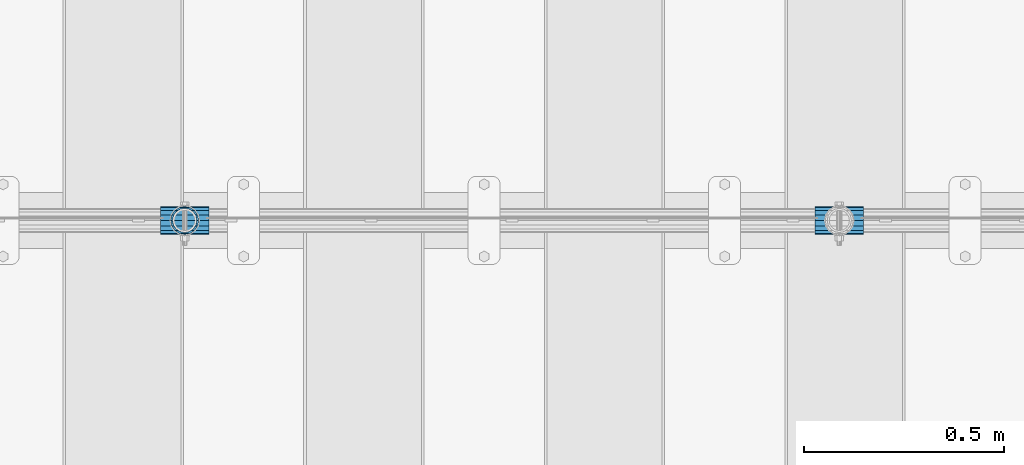
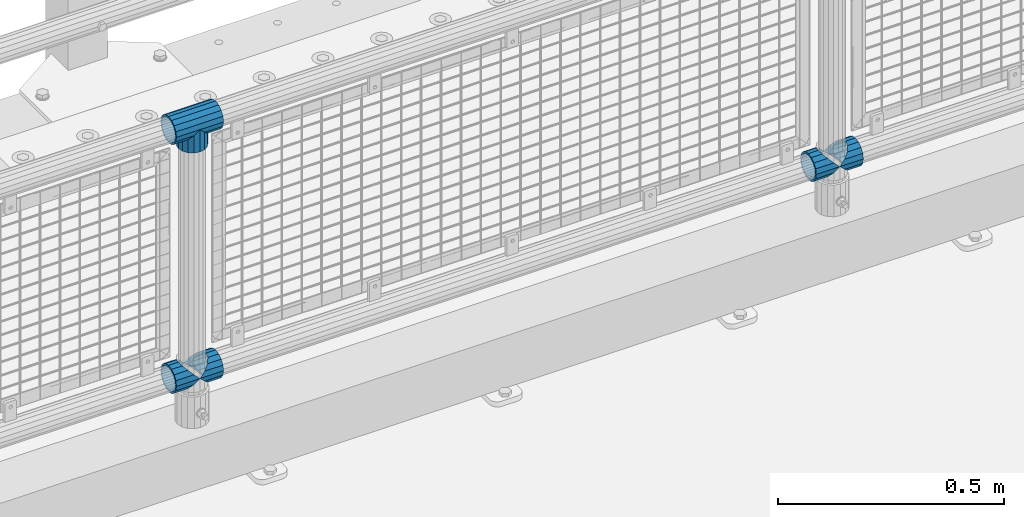
# One storey, part 151 of 242: 6 beams.
"""IFC2X3 building model written with IfcOpenShell, lengths in millimetres."""

from ifc_helpers import new_model, si_unit, frame, origin_with_axes, place, context, subcontext, project, spatial, faceted_brep, material, type_object, element, save


model = new_model("IFC2X3")

# Units and contexts
model_context = context("Model", 3, precision=1e-05, world=origin_with_axes())
body_context = subcontext(model_context, "Body", "Model", "MODEL_VIEW")
ifc_project = project(units=[si_unit("LENGTHUNIT", "METRE", prefix="MILLI"), si_unit("AREAUNIT", "SQUARE_METRE"), si_unit("VOLUMEUNIT", "CUBIC_METRE"), si_unit("MASSUNIT", "GRAM", prefix="KILO"), si_unit("TIMEUNIT", "SECOND"), si_unit("PLANEANGLEUNIT", "RADIAN"), si_unit("SOLIDANGLEUNIT", "STERADIAN"), si_unit("THERMODYNAMICTEMPERATUREUNIT", "DEGREE_CELSIUS"), si_unit("LUMINOUSINTENSITYUNIT", "LUMEN")], contexts=[model_context])

# Site, building, storey
site_placement = place(None, origin_with_axes())
site = spatial("IfcSite", under=ifc_project, at=site_placement, CompositionType="ELEMENT")
building_placement = place(site_placement, origin_with_axes())
building = spatial("IfcBuilding", under=site, at=building_placement, Name="Standard", CompositionType="ELEMENT")
storey_placement = place(building_placement, origin_with_axes())
storey = spatial("IfcBuildingStorey", under=building, at=storey_placement, Name="Undefined", CompositionType="ELEMENT", Elevation=0.0)

# Beams
ifc_material = material(Name="Misc_Undefined")
beam_type = type_object("IfcBeamType", PredefinedType="NOTDEFINED")
beam_1_placement = place(storey_placement, frame((-33724.15, -19335.5, 298.17), z_axis=(0.0, 1.0, 0.0), x_axis=(1.0, 0.0, 0.0)))
element("IfcBeam", 1, at=beam_1_placement, inside=storey, type_object=beam_type, material=ifc_material, context=body_context, shape_type="Brep", body=[
    faceted_brep([(60.1500000000015, 0.0, -35.1500000000015), (46.698677352364, 13.4513226476329, -32.4743655677703), (46.698677352364, -13.4513226476329, -32.4743655677703), (33.0273231408901, 21.4606908090117, 21.46069080901), (27.6756344322275, 26.8123795176754, 13.4513226476338), (27.6756344322275, 32.4743655677717, 13.4513226476338), (35.2951966412911, 24.8548033587072, 24.8548033587067), (35.2951966412911, 16.3810424080013, 24.8548033587067), (27.3102561882806, 28.0397438117175, 11.614442172282), (24.9999999999964, 30.35, 0.0), (24.9999999999964, 35.15, 0.0), (27.6756344322275, 26.8123795176754, -13.4513226476338), (27.6756344322275, 32.4743655677717, -13.4513226476338), (27.310256188277, 28.0397438117175, -11.614442172282), (35.2951966412911, 16.3810424080013, -24.8548033587067), (35.2951966412911, 24.8548033587072, -24.8548033587067), (33.0273231408937, 21.4606908090117, -21.46069080901), (40.061796877013, 11.6144421722805, -28.0397438117179), (43.5193396016293, 0.0, -30.3499999999985), (40.061796877013, -11.6144421722805, -28.0397438117179), (35.2951966412911, -16.3810424080078, -24.8548033587067), (35.2951966412911, -24.8548033587072, -24.8548033587067), (33.0273231408937, -21.4606908090117, -21.46069080901), (27.6756344322275, -26.8123795176754, -13.4513226476338), (27.6756344322275, -32.4743655677717, -13.4513226476338), (27.310256188277, -28.0397438117175, -11.614442172282), (24.9999999999964, -30.35, 0.0), (24.9999999999964, -35.15, 0.0), (27.3102561882806, -28.0397438117175, 11.614442172282), (27.6756344322275, -26.8123795176775, 13.4513226476338), (27.6756344322275, -32.4743655677717, 13.4513226476338), (33.0273231408901, -21.4606908090117, 21.46069080901), (35.2951966412911, -16.3810424080045, 24.8548033587067), (35.2951966412911, -24.8548033587072, 24.8548033587067), (60.1500000000015, 0.0, 35.1500000000015), (46.698677352364, -13.4513226476329, 32.4743655677703), (46.698677352364, 13.4513226476329, 32.4743655677703), (40.0617968770166, -11.6144421722805, 28.0397438117179), (43.5193396016257, 0.0, 30.3499999999985), (40.0617968770166, 11.6144421722805, 28.0397438117179), (0.0, -32.4743655677703, -13.4513226476338), (0.0, -24.8548033587067, -24.8548033587067), (0.0, -13.4513226476338, -32.4743655677739), (0.0, 0.0, -35.1500000000015), (0.0, 13.4513226476338, -32.4743655677739), (0.0, 24.8548033587067, -24.8548033587067), (0.0, 32.4743655677703, -13.4513226476338), (0.0, 35.1500000000015, 0.0), (0.0, 32.4743655677703, 13.4513226476338), (0.0, 24.8548033587067, 24.8548033587067), (0.0, 13.4513226476338, 32.4743655677739), (0.0, 0.0, 35.1500000000015), (0.0, -32.4743655677703, 13.4513226476338), (0.0, -35.1500000000015, 0.0), (0.0, -24.8548033587067, 24.8548033587067), (0.0, -13.4513226476338, 32.4743655677739), (0.0, -28.0397438117179, -11.6144421722784), (0.0, -21.46069080901, -21.4606908090136), (0.0, -11.614442172282, -28.0397438117143), (0.0, 0.0, -30.3499999999985), (0.0, 11.614442172282, -28.0397438117143), (0.0, 21.46069080901, -21.4606908090136), (0.0, 28.0397438117179, -11.6144421722784), (0.0, 30.3499999999985, 0.0), (0.0, 28.0397438117179, 11.6144421722784), (0.0, 21.46069080901, 21.4606908090136), (0.0, 11.614442172282, 28.0397438117143), (0.0, 0.0, 30.3499999999985), (0.0, -11.614442172282, 28.0397438117143), (0.0, -21.46069080901, 21.4606908090136), (0.0, -28.0397438117179, 11.6144421722784), (0.0, -30.3499999999985, 0.0)], [[[0, 1, 2]], [[3, 4, 5, 6, 7]], [[8, 9, 10, 5, 4]], [[11, 12, 10, 9, 13]], [[14, 15, 12, 11, 16]], [[2, 1, 15, 14, 17, 18, 19, 20, 21]], [[21, 20, 22, 23, 24]], [[24, 23, 25, 26, 27]], [[27, 26, 28, 29, 30]], [[30, 29, 31, 32, 33]], [[34, 35, 36]], [[33, 32, 37, 38, 39, 7, 6, 36, 35]], [[40, 41, 21, 24]], [[41, 42, 2, 21]], [[42, 43, 0, 2]], [[43, 44, 1, 0]], [[44, 45, 15, 1]], [[45, 46, 12, 15]], [[46, 47, 10, 12]], [[47, 48, 5, 10]], [[48, 49, 6, 5]], [[49, 50, 36, 6]], [[50, 51, 34, 36]], [[52, 53, 27, 30]], [[54, 52, 30, 33]], [[55, 54, 33, 35]], [[51, 55, 35, 34]], [[53, 40, 24, 27]], [[52, 54, 55, 51, 50, 49, 48, 47, 46, 45, 44, 43, 42, 41, 40, 53], [56, 57, 58, 59, 60, 61, 62, 63, 64, 65, 66, 67, 68, 69, 70, 71]], [[68, 67, 38, 37]], [[31, 69, 68, 37, 32]], [[28, 70, 69, 31, 29]], [[71, 70, 28, 26]], [[56, 71, 26, 25]], [[57, 56, 25, 23, 22]], [[58, 57, 22, 20, 19]], [[59, 58, 19, 18]], [[60, 59, 18, 17]], [[16, 61, 60, 17, 14]], [[13, 62, 61, 16, 11]], [[63, 62, 13, 9]], [[64, 63, 9, 8]], [[65, 64, 8, 4, 3]], [[66, 65, 3, 7, 39]], [[67, 66, 39, 38]]]),
])
beam_2_placement = place(storey_placement, frame((-33664.0, -19335.5, 298.17), z_axis=(0.0, 1.0, 0.0), x_axis=(1.0, 0.0, 0.0)))
element("IfcBeam", 2, at=beam_2_placement, inside=storey, type_object=beam_type, material=ifc_material, context=body_context, shape_type="Brep", body=[
    faceted_brep([(13.4513226476338, 13.4513226476329, 32.4743655677703), (13.4513226476338, -13.4513226476329, 32.4743655677703), (0.0, 0.0, 35.1500000000015), (27.122676859115, -21.4606908090117, -21.46069080901), (24.8548033587067, -16.3810424080019, -24.8548033587067), (24.8548033587067, -24.8548033587072, -24.8548033587067), (32.4743655677739, -32.4743655677717, -13.4513226476338), (32.4743655677739, -26.8123795176754, -13.4513226476338), (0.0, 0.0, -35.1500000000015), (13.4513226476338, -13.4513226476329, -32.4743655677703), (13.4513226476338, 13.4513226476329, -32.4743655677703), (20.0882031229849, -11.6144421722805, -28.0397438117179), (16.6306603983758, 0.0, -30.3499999999985), (20.0882031229849, 11.6144421722805, -28.0397438117179), (24.8548033587067, 16.3810424079986, -24.8548033587067), (24.8548033587067, 24.8548033587072, -24.8548033587067), (27.122676859115, 21.4606908090117, -21.46069080901), (32.4743655677739, 26.8123795176776, -13.4513226476338), (32.4743655677739, 32.4743655677717, -13.4513226476338), (32.8397438117099, 28.0397438117175, -11.614442172282), (35.1500000000015, 30.35, 0.0), (35.1500000000015, 35.1499999999996, 0.0), (32.8397438117172, 28.0397438117175, 11.614442172282), (32.4743655677739, 26.8123795176754, 13.4513226476338), (32.4743655677739, 32.4743655677717, 13.4513226476338), (27.1226768591077, 21.4606908090117, 21.46069080901), (24.8548033587067, 16.3810424080019, 24.8548033587067), (24.8548033587067, 24.8548033587072, 24.8548033587067), (20.0882031229849, 11.6144421722805, 28.0397438117179), (16.6306603983685, 0.0, 30.3499999999985), (20.0882031229849, -11.6144421722805, 28.0397438117179), (24.8548033587067, -16.3810424080019, 24.8548033587067), (24.8548033587067, -24.8548033587072, 24.8548033587067), (32.4743655677739, -26.8123795176754, 13.4513226476338), (32.4743655677739, -32.4743655677717, 13.4513226476338), (27.1226768591077, -21.4606908090117, 21.46069080901), (35.1500000000015, -30.35, 0.0), (35.1500000000015, -35.15, 0.0), (32.8397438117172, -28.0397438117175, 11.614442172282), (32.8397438117099, -28.0397438117175, -11.614442172282), (60.1500000000015, -24.8548033587072, -24.8548033587067), (60.1500000000015, -32.4743655677717, -13.4513226476338), (60.1500000000015, -13.4513226476329, -32.4743655677703), (60.1500000000015, 0.0, -35.1500000000015), (60.1500000000015, 13.4513226476329, -32.4743655677703), (60.1500000000015, 24.8548033587072, -24.8548033587067), (60.1500000000015, 32.4743655677717, -13.4513226476338), (60.1500000000015, 35.15, 0.0), (60.1500000000015, 32.4743655677717, 13.4513226476338), (60.1500000000015, 24.8548033587072, 24.8548033587067), (60.1500000000015, 13.4513226476329, 32.4743655677703), (60.1500000000015, 0.0, 35.1500000000015), (60.1500000000015, -13.4513226476329, 32.4743655677703), (60.1500000000015, -24.8548033587072, 24.8548033587067), (60.1500000000015, -32.4743655677717, 13.4513226476338), (60.1500000000015, -35.15, 0.0), (60.1500000000015, -21.4606908090117, 21.46069080901), (60.1500000000015, -11.6144421722805, 28.0397438117179), (60.1500000000015, 0.0, 30.3499999999985), (60.1500000000015, 11.6144421722805, 28.0397438117179), (60.1500000000015, 21.4606908090117, 21.46069080901), (60.1500000000015, 28.0397438117175, 11.614442172282), (60.1500000000015, 30.35, 0.0), (60.1500000000015, 28.0397438117175, -11.614442172282), (60.1500000000015, 21.4606908090117, -21.46069080901), (60.1500000000015, 11.6144421722805, -28.0397438117179), (60.1500000000015, 0.0, -30.3499999999985), (60.1500000000015, -11.6144421722805, -28.0397438117179), (60.1500000000015, -21.4606908090117, -21.46069080901), (60.1500000000015, -28.0397438117175, -11.614442172282), (60.1500000000015, -30.35, 0.0), (60.1500000000015, -28.0397438117175, 11.614442172282)], [[[0, 1, 2]], [[3, 4, 5, 6, 7]], [[8, 9, 10]], [[10, 9, 5, 4, 11, 12, 13, 14, 15]], [[15, 14, 16, 17, 18]], [[18, 17, 19, 20, 21]], [[21, 20, 22, 23, 24]], [[24, 23, 25, 26, 27]], [[27, 26, 28, 29, 30, 31, 32, 1, 0]], [[33, 34, 32, 31, 35]], [[36, 37, 34, 33, 38]], [[39, 7, 6, 37, 36]], [[40, 41, 6, 5]], [[42, 40, 5, 9]], [[43, 42, 9, 8]], [[44, 43, 8, 10]], [[45, 44, 10, 15]], [[46, 45, 15, 18]], [[47, 46, 18, 21]], [[48, 47, 21, 24]], [[49, 48, 24, 27]], [[50, 49, 27, 0]], [[51, 50, 0, 2]], [[52, 51, 2, 1]], [[53, 52, 1, 32]], [[54, 53, 32, 34]], [[55, 54, 34, 37]], [[41, 55, 37, 6]], [[40, 42, 43, 44, 45, 46, 47, 48, 49, 50, 51, 52, 53, 54, 55, 41], [56, 57, 58, 59, 60, 61, 62, 63, 64, 65, 66, 67, 68, 69, 70, 71]], [[71, 70, 36, 38]], [[35, 56, 71, 38, 33]], [[30, 57, 56, 35, 31]], [[58, 57, 30, 29]], [[59, 58, 29, 28]], [[60, 59, 28, 26, 25]], [[61, 60, 25, 23, 22]], [[62, 61, 22, 20]], [[63, 62, 20, 19]], [[16, 64, 63, 19, 17]], [[13, 65, 64, 16, 14]], [[66, 65, 13, 12]], [[67, 66, 12, 11]], [[68, 67, 11, 4, 3]], [[69, 68, 3, 7, 39]], [[70, 69, 39, 36]]]),
])
beam_3_placement = place(storey_placement, frame((-35357.15, -19335.5, 298.17), z_axis=(0.0, 1.0, 0.0), x_axis=(1.0, 0.0, 0.0)))
element("IfcBeam", 3, at=beam_3_placement, inside=storey, type_object=beam_type, material=ifc_material, context=body_context, shape_type="Brep", body=[
    faceted_brep([(60.1500000000015, 0.0, -35.1500000000015), (46.698677352364, 13.4513226476329, -32.4743655677703), (46.698677352364, -13.4513226476329, -32.4743655677703), (33.0273231408901, 21.4606908090117, 21.46069080901), (27.6756344322275, 26.8123795176754, 13.4513226476338), (27.6756344322275, 32.4743655677717, 13.4513226476338), (35.2951966412911, 24.8548033587072, 24.8548033587067), (35.2951966412911, 16.3810424080013, 24.8548033587067), (27.3102561882806, 28.0397438117175, 11.614442172282), (24.9999999999964, 30.35, 0.0), (24.9999999999964, 35.15, 0.0), (27.6756344322275, 26.8123795176754, -13.4513226476338), (27.6756344322275, 32.4743655677717, -13.4513226476338), (27.310256188277, 28.0397438117175, -11.614442172282), (35.2951966412911, 16.3810424080013, -24.8548033587067), (35.2951966412911, 24.8548033587072, -24.8548033587067), (33.0273231408937, 21.4606908090117, -21.46069080901), (40.061796877013, 11.6144421722805, -28.0397438117179), (43.5193396016293, 0.0, -30.3499999999985), (40.061796877013, -11.6144421722805, -28.0397438117179), (35.2951966412911, -16.3810424080078, -24.8548033587067), (35.2951966412911, -24.8548033587072, -24.8548033587067), (33.0273231408937, -21.4606908090117, -21.46069080901), (27.6756344322275, -26.8123795176754, -13.4513226476338), (27.6756344322275, -32.4743655677717, -13.4513226476338), (27.310256188277, -28.0397438117175, -11.614442172282), (24.9999999999964, -30.35, 0.0), (24.9999999999964, -35.15, 0.0), (27.3102561882806, -28.0397438117175, 11.614442172282), (27.6756344322275, -26.8123795176775, 13.4513226476338), (27.6756344322275, -32.4743655677717, 13.4513226476338), (33.0273231408901, -21.4606908090117, 21.46069080901), (35.2951966412911, -16.3810424080045, 24.8548033587067), (35.2951966412911, -24.8548033587072, 24.8548033587067), (60.1500000000015, 0.0, 35.1500000000015), (46.698677352364, -13.4513226476329, 32.4743655677703), (46.698677352364, 13.4513226476329, 32.4743655677703), (40.0617968770166, -11.6144421722805, 28.0397438117179), (43.5193396016257, 0.0, 30.3499999999985), (40.0617968770166, 11.6144421722805, 28.0397438117179), (0.0, -32.4743655677703, -13.4513226476338), (0.0, -24.8548033587067, -24.8548033587067), (0.0, -13.4513226476338, -32.4743655677739), (0.0, 0.0, -35.1500000000015), (0.0, 13.4513226476338, -32.4743655677739), (0.0, 24.8548033587067, -24.8548033587067), (0.0, 32.4743655677703, -13.4513226476338), (0.0, 35.1500000000015, 0.0), (0.0, 32.4743655677703, 13.4513226476338), (0.0, 24.8548033587067, 24.8548033587067), (0.0, 13.4513226476338, 32.4743655677739), (0.0, 0.0, 35.1500000000015), (0.0, -32.4743655677703, 13.4513226476338), (0.0, -35.1500000000015, 0.0), (0.0, -24.8548033587067, 24.8548033587067), (0.0, -13.4513226476338, 32.4743655677739), (0.0, -28.0397438117179, -11.6144421722784), (0.0, -21.46069080901, -21.4606908090136), (0.0, -11.614442172282, -28.0397438117143), (0.0, 0.0, -30.3499999999985), (0.0, 11.614442172282, -28.0397438117143), (0.0, 21.46069080901, -21.4606908090136), (0.0, 28.0397438117179, -11.6144421722784), (0.0, 30.3499999999985, 0.0), (0.0, 28.0397438117179, 11.6144421722784), (0.0, 21.46069080901, 21.4606908090136), (0.0, 11.614442172282, 28.0397438117143), (0.0, 0.0, 30.3499999999985), (0.0, -11.614442172282, 28.0397438117143), (0.0, -21.46069080901, 21.4606908090136), (0.0, -28.0397438117179, 11.6144421722784), (0.0, -30.3499999999985, 0.0)], [[[0, 1, 2]], [[3, 4, 5, 6, 7]], [[8, 9, 10, 5, 4]], [[11, 12, 10, 9, 13]], [[14, 15, 12, 11, 16]], [[2, 1, 15, 14, 17, 18, 19, 20, 21]], [[21, 20, 22, 23, 24]], [[24, 23, 25, 26, 27]], [[27, 26, 28, 29, 30]], [[30, 29, 31, 32, 33]], [[34, 35, 36]], [[33, 32, 37, 38, 39, 7, 6, 36, 35]], [[40, 41, 21, 24]], [[41, 42, 2, 21]], [[42, 43, 0, 2]], [[43, 44, 1, 0]], [[44, 45, 15, 1]], [[45, 46, 12, 15]], [[46, 47, 10, 12]], [[47, 48, 5, 10]], [[48, 49, 6, 5]], [[49, 50, 36, 6]], [[50, 51, 34, 36]], [[52, 53, 27, 30]], [[54, 52, 30, 33]], [[55, 54, 33, 35]], [[51, 55, 35, 34]], [[53, 40, 24, 27]], [[52, 54, 55, 51, 50, 49, 48, 47, 46, 45, 44, 43, 42, 41, 40, 53], [56, 57, 58, 59, 60, 61, 62, 63, 64, 65, 66, 67, 68, 69, 70, 71]], [[68, 67, 38, 37]], [[31, 69, 68, 37, 32]], [[28, 70, 69, 31, 29]], [[71, 70, 28, 26]], [[56, 71, 26, 25]], [[57, 56, 25, 23, 22]], [[58, 57, 22, 20, 19]], [[59, 58, 19, 18]], [[60, 59, 18, 17]], [[16, 61, 60, 17, 14]], [[13, 62, 61, 16, 11]], [[63, 62, 13, 9]], [[64, 63, 9, 8]], [[65, 64, 8, 4, 3]], [[66, 65, 3, 7, 39]], [[67, 66, 39, 38]]]),
])
beam_4_placement = place(storey_placement, frame((-35297.0, -19335.5, 298.17), z_axis=(0.0, 1.0, 0.0), x_axis=(1.0, 0.0, 0.0)))
element("IfcBeam", 4, at=beam_4_placement, inside=storey, type_object=beam_type, material=ifc_material, context=body_context, shape_type="Brep", body=[
    faceted_brep([(13.4513226476338, 13.4513226476329, 32.4743655677703), (13.4513226476338, -13.4513226476329, 32.4743655677703), (0.0, 0.0, 35.1500000000015), (27.122676859115, -21.4606908090117, -21.46069080901), (24.8548033587067, -16.3810424080019, -24.8548033587067), (24.8548033587067, -24.8548033587072, -24.8548033587067), (32.4743655677739, -32.4743655677717, -13.4513226476338), (32.4743655677739, -26.8123795176754, -13.4513226476338), (0.0, 0.0, -35.1500000000015), (13.4513226476338, -13.4513226476329, -32.4743655677703), (13.4513226476338, 13.4513226476329, -32.4743655677703), (20.0882031229849, -11.6144421722805, -28.0397438117179), (16.6306603983758, 0.0, -30.3499999999985), (20.0882031229849, 11.6144421722805, -28.0397438117179), (24.8548033587067, 16.3810424079986, -24.8548033587067), (24.8548033587067, 24.8548033587072, -24.8548033587067), (27.122676859115, 21.4606908090117, -21.46069080901), (32.4743655677739, 26.8123795176776, -13.4513226476338), (32.4743655677739, 32.4743655677717, -13.4513226476338), (32.8397438117099, 28.0397438117175, -11.614442172282), (35.1500000000015, 30.35, 0.0), (35.1500000000015, 35.1499999999996, 0.0), (32.8397438117172, 28.0397438117175, 11.614442172282), (32.4743655677739, 26.8123795176754, 13.4513226476338), (32.4743655677739, 32.4743655677717, 13.4513226476338), (27.1226768591077, 21.4606908090117, 21.46069080901), (24.8548033587067, 16.3810424080019, 24.8548033587067), (24.8548033587067, 24.8548033587072, 24.8548033587067), (20.0882031229849, 11.6144421722805, 28.0397438117179), (16.6306603983685, 0.0, 30.3499999999985), (20.0882031229849, -11.6144421722805, 28.0397438117179), (24.8548033587067, -16.3810424080019, 24.8548033587067), (24.8548033587067, -24.8548033587072, 24.8548033587067), (32.4743655677739, -26.8123795176754, 13.4513226476338), (32.4743655677739, -32.4743655677717, 13.4513226476338), (27.1226768591077, -21.4606908090117, 21.46069080901), (35.1500000000015, -30.35, 0.0), (35.1500000000015, -35.15, 0.0), (32.8397438117172, -28.0397438117175, 11.614442172282), (32.8397438117099, -28.0397438117175, -11.614442172282), (60.1500000000015, -24.8548033587072, -24.8548033587067), (60.1500000000015, -32.4743655677717, -13.4513226476338), (60.1500000000015, -13.4513226476329, -32.4743655677703), (60.1500000000015, 0.0, -35.1500000000015), (60.1500000000015, 13.4513226476329, -32.4743655677703), (60.1500000000015, 24.8548033587072, -24.8548033587067), (60.1500000000015, 32.4743655677717, -13.4513226476338), (60.1500000000015, 35.15, 0.0), (60.1500000000015, 32.4743655677717, 13.4513226476338), (60.1500000000015, 24.8548033587072, 24.8548033587067), (60.1500000000015, 13.4513226476329, 32.4743655677703), (60.1500000000015, 0.0, 35.1500000000015), (60.1500000000015, -13.4513226476329, 32.4743655677703), (60.1500000000015, -24.8548033587072, 24.8548033587067), (60.1500000000015, -32.4743655677717, 13.4513226476338), (60.1500000000015, -35.15, 0.0), (60.1500000000015, -21.4606908090117, 21.46069080901), (60.1500000000015, -11.6144421722805, 28.0397438117179), (60.1500000000015, 0.0, 30.3499999999985), (60.1500000000015, 11.6144421722805, 28.0397438117179), (60.1500000000015, 21.4606908090117, 21.46069080901), (60.1500000000015, 28.0397438117175, 11.614442172282), (60.1500000000015, 30.35, 0.0), (60.1500000000015, 28.0397438117175, -11.614442172282), (60.1500000000015, 21.4606908090117, -21.46069080901), (60.1500000000015, 11.6144421722805, -28.0397438117179), (60.1500000000015, 0.0, -30.3499999999985), (60.1500000000015, -11.6144421722805, -28.0397438117179), (60.1500000000015, -21.4606908090117, -21.46069080901), (60.1500000000015, -28.0397438117175, -11.614442172282), (60.1500000000015, -30.35, 0.0), (60.1500000000015, -28.0397438117175, 11.614442172282)], [[[0, 1, 2]], [[3, 4, 5, 6, 7]], [[8, 9, 10]], [[10, 9, 5, 4, 11, 12, 13, 14, 15]], [[15, 14, 16, 17, 18]], [[18, 17, 19, 20, 21]], [[21, 20, 22, 23, 24]], [[24, 23, 25, 26, 27]], [[27, 26, 28, 29, 30, 31, 32, 1, 0]], [[33, 34, 32, 31, 35]], [[36, 37, 34, 33, 38]], [[39, 7, 6, 37, 36]], [[40, 41, 6, 5]], [[42, 40, 5, 9]], [[43, 42, 9, 8]], [[44, 43, 8, 10]], [[45, 44, 10, 15]], [[46, 45, 15, 18]], [[47, 46, 18, 21]], [[48, 47, 21, 24]], [[49, 48, 24, 27]], [[50, 49, 27, 0]], [[51, 50, 0, 2]], [[52, 51, 2, 1]], [[53, 52, 1, 32]], [[54, 53, 32, 34]], [[55, 54, 34, 37]], [[41, 55, 37, 6]], [[40, 42, 43, 44, 45, 46, 47, 48, 49, 50, 51, 52, 53, 54, 55, 41], [56, 57, 58, 59, 60, 61, 62, 63, 64, 65, 66, 67, 68, 69, 70, 71]], [[71, 70, 36, 38]], [[35, 56, 71, 38, 33]], [[30, 57, 56, 35, 31]], [[58, 57, 30, 29]], [[59, 58, 29, 28]], [[60, 59, 28, 26, 25]], [[61, 60, 25, 23, 22]], [[62, 61, 22, 20]], [[63, 62, 20, 19]], [[16, 64, 63, 19, 17]], [[13, 65, 64, 16, 14]], [[66, 65, 13, 12]], [[67, 66, 12, 11]], [[68, 67, 11, 4, 3]], [[69, 68, 3, 7, 39]], [[70, 69, 39, 36]]]),
])
beam_5_placement = place(storey_placement, frame((-35297.0, -19335.5, 969.849999999999), z_axis=(0.0, 1.0, 0.0), x_axis=(0.0, 0.0, -1.0)))
element("IfcBeam", 5, at=beam_5_placement, inside=storey, type_object=beam_type, material=ifc_material, context=body_context, shape_type="Brep", body=[
    faceted_brep([(13.4513226476338, 13.4513226476329, 32.4743655677703), (13.4513226476338, -13.4513226476329, 32.4743655677703), (0.0, 0.0, 35.1500000000015), (27.122676859115, -21.4606908090117, -21.46069080901), (24.8548033587067, -16.3810424080019, -24.8548033587067), (24.8548033587067, -24.8548033587072, -24.8548033587067), (32.4743655677739, -32.4743655677717, -13.4513226476338), (32.4743655677739, -26.8123795176754, -13.4513226476338), (0.0, 0.0, -35.1500000000015), (13.4513226476338, -13.4513226476329, -32.4743655677703), (13.4513226476338, 13.4513226476329, -32.4743655677703), (20.0882031229849, -11.6144421722805, -28.0397438117179), (16.6306603983758, 0.0, -30.3499999999985), (20.0882031229849, 11.6144421722805, -28.0397438117179), (24.8548033587067, 16.3810424079986, -24.8548033587067), (24.8548033587067, 24.8548033587072, -24.8548033587067), (27.122676859115, 21.4606908090117, -21.46069080901), (32.4743655677739, 26.8123795176776, -13.4513226476338), (32.4743655677739, 32.4743655677717, -13.4513226476338), (32.8397438117099, 28.0397438117175, -11.614442172282), (35.1500000000015, 30.35, 0.0), (35.1500000000015, 35.1499999999996, 0.0), (32.8397438117172, 28.0397438117175, 11.614442172282), (32.4743655677739, 26.8123795176754, 13.4513226476338), (32.4743655677739, 32.4743655677717, 13.4513226476338), (27.1226768591077, 21.4606908090117, 21.46069080901), (24.8548033587067, 16.3810424080019, 24.8548033587067), (24.8548033587067, 24.8548033587072, 24.8548033587067), (20.0882031229849, 11.6144421722805, 28.0397438117179), (16.6306603983685, 0.0, 30.3499999999985), (20.0882031229849, -11.6144421722805, 28.0397438117179), (24.8548033587067, -16.3810424080019, 24.8548033587067), (24.8548033587067, -24.8548033587072, 24.8548033587067), (32.4743655677739, -26.8123795176754, 13.4513226476338), (32.4743655677739, -32.4743655677717, 13.4513226476338), (27.1226768591077, -21.4606908090117, 21.46069080901), (35.1500000000015, -30.35, 0.0), (35.1500000000015, -35.15, 0.0), (32.8397438117172, -28.0397438117175, 11.614442172282), (32.8397438117099, -28.0397438117175, -11.614442172282), (60.1500000000015, -24.8548033587072, -24.8548033587067), (60.1500000000015, -32.4743655677717, -13.4513226476338), (60.1500000000015, -13.4513226476329, -32.4743655677703), (60.1500000000015, 0.0, -35.1500000000015), (60.1500000000015, 13.4513226476329, -32.4743655677703), (60.1500000000015, 24.8548033587072, -24.8548033587067), (60.1500000000015, 32.4743655677717, -13.4513226476338), (60.1500000000015, 35.15, 0.0), (60.1500000000015, 32.4743655677717, 13.4513226476338), (60.1500000000015, 24.8548033587072, 24.8548033587067), (60.1500000000015, 13.4513226476329, 32.4743655677703), (60.1500000000015, 0.0, 35.1500000000015), (60.1500000000015, -13.4513226476329, 32.4743655677703), (60.1500000000015, -24.8548033587072, 24.8548033587067), (60.1500000000015, -32.4743655677717, 13.4513226476338), (60.1500000000015, -35.15, 0.0), (60.1500000000015, -21.4606908090117, 21.46069080901), (60.1500000000015, -11.6144421722805, 28.0397438117179), (60.1500000000015, 0.0, 30.3499999999985), (60.1500000000015, 11.6144421722805, 28.0397438117179), (60.1500000000015, 21.4606908090117, 21.46069080901), (60.1500000000015, 28.0397438117175, 11.614442172282), (60.1500000000015, 30.35, 0.0), (60.1500000000015, 28.0397438117175, -11.614442172282), (60.1500000000015, 21.4606908090117, -21.46069080901), (60.1500000000015, 11.6144421722805, -28.0397438117179), (60.1500000000015, 0.0, -30.3499999999985), (60.1500000000015, -11.6144421722805, -28.0397438117179), (60.1500000000015, -21.4606908090117, -21.46069080901), (60.1500000000015, -28.0397438117175, -11.614442172282), (60.1500000000015, -30.35, 0.0), (60.1500000000015, -28.0397438117175, 11.614442172282)], [[[0, 1, 2]], [[3, 4, 5, 6, 7]], [[8, 9, 10]], [[10, 9, 5, 4, 11, 12, 13, 14, 15]], [[15, 14, 16, 17, 18]], [[18, 17, 19, 20, 21]], [[21, 20, 22, 23, 24]], [[24, 23, 25, 26, 27]], [[27, 26, 28, 29, 30, 31, 32, 1, 0]], [[33, 34, 32, 31, 35]], [[36, 37, 34, 33, 38]], [[39, 7, 6, 37, 36]], [[40, 41, 6, 5]], [[42, 40, 5, 9]], [[43, 42, 9, 8]], [[44, 43, 8, 10]], [[45, 44, 10, 15]], [[46, 45, 15, 18]], [[47, 46, 18, 21]], [[48, 47, 21, 24]], [[49, 48, 24, 27]], [[50, 49, 27, 0]], [[51, 50, 0, 2]], [[52, 51, 2, 1]], [[53, 52, 1, 32]], [[54, 53, 32, 34]], [[55, 54, 34, 37]], [[41, 55, 37, 6]], [[40, 42, 43, 44, 45, 46, 47, 48, 49, 50, 51, 52, 53, 54, 55, 41], [56, 57, 58, 59, 60, 61, 62, 63, 64, 65, 66, 67, 68, 69, 70, 71]], [[71, 70, 36, 38]], [[35, 56, 71, 38, 33]], [[30, 57, 56, 35, 31]], [[58, 57, 30, 29]], [[59, 58, 29, 28]], [[60, 59, 28, 26, 25]], [[61, 60, 25, 23, 22]], [[62, 61, 22, 20]], [[63, 62, 20, 19]], [[16, 64, 63, 19, 17]], [[13, 65, 64, 16, 14]], [[66, 65, 13, 12]], [[67, 66, 12, 11]], [[68, 67, 11, 4, 3]], [[69, 68, 3, 7, 39]], [[70, 69, 39, 36]]]),
])
beam_6_placement = place(storey_placement, frame((-35357.15, -19335.5, 969.849999999999), z_axis=(0.0, 0.0, 1.0), x_axis=(1.0, 0.0, 0.0)))
element("IfcBeam", 6, at=beam_6_placement, inside=storey, type_object=beam_type, material=ifc_material, context=body_context, shape_type="Brep", body=[
    faceted_brep([(88.1897438117194, -11.614442172282, -28.0397438117176), (88.1897438117194, -11.614442172282, -32.8397438117175), (86.9623795176813, -13.4513226476338, -32.4743655677718), (81.6106908090114, -21.46069080901, -27.12267685911), (81.6106908090114, -21.46069080901, -21.4606908090117), (76.5310424080017, -24.8548033587067, -24.8548033587072), (71.7644421722835, -28.0397438117179, -20.0882031229829), (71.7644421722835, -28.0397438117179, -11.6144421722805), (60.1500000000015, -30.3499999999985, -16.6306603983671), (60.1500000000015, -30.35, 0.0), (48.5355578277195, -28.0397438117179, -20.0882031229829), (48.5355578277195, -28.0397438117179, -11.6144421722805), (43.7689575920012, -24.8548033587067, -24.8548033587072), (38.6893091909915, -21.46069080901, -27.12267685911), (38.6893091909915, -21.46069080901, -21.4606908090117), (33.3376204823289, -13.4513226476338, -32.4743655677718), (32.1102561882835, -11.614442172282, -32.8397438117175), (32.1102561882835, -11.614442172282, -28.0397438117176), (29.8000000000029, 0.0, -35.15), (29.8000000000029, 0.0, -30.35), (32.1102561882835, 11.614442172282, -32.8397438117171), (32.1102561882835, 11.614442172282, -28.0397438117176), (33.3376204823253, 13.4513226476338, -32.4743655677718), (38.6893091909915, 21.46069080901, -27.12267685911), (38.6893091909915, 21.46069080901, -21.4606908090117), (43.7689575920012, 24.8548033587067, -24.8548033587072), (48.5355578277195, 28.0397438117179, -20.0882031229861), (48.5355578277195, 28.0397438117179, -11.6144421722805), (60.1500000000015, 30.3499999999985, -16.6306603983737), (60.1500000000015, 30.35, 0.0), (71.7644421722835, 28.0397438117179, -20.0882031229861), (71.7644421722835, 28.0397438117179, -11.6144421722805), (76.5310424080017, 24.8548033587067, -24.8548033587072), (81.6106908090114, 21.46069080901, -27.12267685911), (81.6106908090114, 21.46069080901, -21.4606908090117), (86.9623795176667, 13.4513226476338, -32.4743655677718), (88.1897438117194, 11.614442172282, -32.8397438117171), (88.1897438117194, 11.614442172282, -28.0397438117176), (90.5, 0.0, -35.15), (90.5, 0.0, -30.35), (0.0, -21.46069080901, -21.4606908090136), (0.0, -28.0397438117179, -11.6144421722784), (0.0, -11.614442172282, -28.0397438117143), (0.0, 0.0, -30.3499999999985), (0.0, 11.614442172282, -28.0397438117143), (0.0, 21.46069080901, -21.4606908090136), (0.0, 28.0397438117179, -11.6144421722784), (0.0, 30.3499999999985, 0.0), (0.0, 32.4743655677703, -13.4513226476338), (0.0, 35.1500000000015, 0.0), (120.299999999999, 35.1500000000015, 0.0), (120.299999999999, 32.4743655677703, -13.4513226476329), (0.0, 32.4743655677703, 13.4513226476338), (120.299999999999, 32.4743655677703, 13.4513226476329), (0.0, 24.8548033587067, 24.8548033587067), (120.299999999999, 24.8548033587067, 24.8548033587072), (0.0, 13.4513226476338, 32.4743655677739), (120.299999999999, 13.4513226476338, 32.4743655677718), (0.0, 0.0, 35.1500000000015), (120.299999999999, 0.0, 35.15), (0.0, -13.4513226476338, 32.4743655677739), (120.299999999999, -13.4513226476338, 32.4743655677718), (0.0, -24.8548033587067, 24.8548033587067), (120.299999999999, -24.8548033587067, 24.8548033587072), (0.0, -32.4743655677703, 13.4513226476338), (120.299999999999, -32.4743655677703, 13.4513226476329), (0.0, -35.1500000000015, 0.0), (120.299999999999, -35.1500000000015, 0.0), (0.0, -32.4743655677703, -13.4513226476338), (120.299999999999, -32.4743655677703, -13.4513226476329), (0.0, 24.8548033587067, -24.8548033587067), (0.0, 13.4513226476338, -32.4743655677739), (0.0, 0.0, -35.1500000000015), (0.0, -13.4513226476338, -32.4743655677739), (0.0, -24.8548033587067, -24.8548033587067), (0.0, 28.0397438117179, 11.6144421722784), (0.0, 21.46069080901, 21.4606908090136), (0.0, 11.614442172282, 28.0397438117143), (0.0, 0.0, 30.3499999999985), (0.0, -11.614442172282, 28.0397438117143), (0.0, -21.46069080901, 21.4606908090136), (0.0, -28.0397438117179, 11.6144421722784), (0.0, -30.3499999999985, 0.0), (120.299999999999, -30.3499999999985, 0.0), (120.299999999999, -28.0397438117179, -11.6144421722805), (120.299999999999, -21.46069080901, -21.4606908090117), (120.299999999999, -11.614442172282, -28.0397438117176), (120.299999999999, 0.0, -30.35), (120.299999999999, 21.46069080901, -21.4606908090117), (120.299999999999, 28.0397438117179, -11.6144421722805), (120.299999999999, 11.614442172282, -28.0397438117176), (120.299999999999, 30.3499999999985, 0.0), (120.299999999999, 28.0397438117179, 11.6144421722805), (120.299999999999, 21.46069080901, 21.4606908090117), (120.299999999999, 11.614442172282, 28.0397438117176), (120.299999999999, 0.0, 30.35), (120.299999999999, -11.614442172282, 28.0397438117176), (120.299999999999, -21.46069080901, 21.4606908090117), (120.299999999999, -28.0397438117179, 11.6144421722805), (120.299999999999, -24.8548033587067, -24.8548033587072), (120.299999999999, -13.4513226476338, -32.4743655677718), (120.299999999999, 0.0, -35.15), (120.299999999999, 13.4513226476338, -32.4743655677718), (120.299999999999, 24.8548033587067, -24.8548033587072)], [[[0, 1, 2, 3, 4]], [[4, 3, 5, 6, 7]], [[7, 6, 8, 9]], [[9, 8, 10, 11]], [[11, 10, 12, 13, 14]], [[14, 13, 15, 16, 17]], [[17, 16, 18, 19]], [[19, 18, 20, 21]], [[21, 20, 22, 23, 24]], [[24, 23, 25, 26, 27]], [[27, 26, 28, 29]], [[29, 28, 30, 31]], [[31, 30, 32, 33, 34]], [[34, 33, 35, 36, 37]], [[37, 36, 38, 39]], [[39, 38, 1, 0]], [[40, 41, 11, 14]], [[42, 40, 14, 17]], [[43, 42, 17, 19]], [[44, 43, 19, 21]], [[45, 44, 21, 24]], [[46, 45, 24, 27]], [[47, 46, 27, 29]], [[48, 49, 50, 51]], [[49, 52, 53, 50]], [[52, 54, 55, 53]], [[54, 56, 57, 55]], [[56, 58, 59, 57]], [[58, 60, 61, 59]], [[60, 62, 63, 61]], [[62, 64, 65, 63]], [[64, 66, 67, 65]], [[66, 68, 69, 67]], [[64, 62, 60, 58, 56, 54, 52, 49, 48, 70, 71, 72, 73, 74, 68, 66], [41, 40, 42, 43, 44, 45, 46, 47, 75, 76, 77, 78, 79, 80, 81, 82]], [[41, 82, 9, 11]], [[83, 84, 7, 9]], [[84, 85, 4, 7]], [[85, 86, 0, 4]], [[86, 87, 39, 0]], [[88, 89, 31, 34]], [[90, 88, 34, 37]], [[87, 90, 37, 39]], [[89, 91, 29, 31]], [[75, 47, 29, 91, 92]], [[76, 75, 92, 93]], [[77, 76, 93, 94]], [[78, 77, 94, 95]], [[79, 78, 95, 96]], [[80, 79, 96, 97]], [[81, 80, 97, 98]], [[9, 82, 81, 98, 83]], [[99, 100, 101, 102, 103, 51, 50, 53, 55, 57, 59, 61, 63, 65, 67, 69], [97, 96, 95, 94, 93, 92, 91, 89, 88, 90, 87, 86, 85, 84, 83, 98]], [[35, 102, 101, 38, 36]], [[32, 103, 102, 35, 33]], [[28, 26, 25, 70, 48, 51, 103, 32, 30]], [[22, 71, 70, 25, 23]], [[18, 72, 71, 22, 20]], [[73, 72, 18, 16, 15]], [[74, 73, 15, 13, 12]], [[99, 69, 68, 74, 12, 10, 8, 6, 5]], [[100, 99, 5, 3, 2]], [[101, 100, 2, 1, 38]]]),
])

save(model, "model.ifc")
